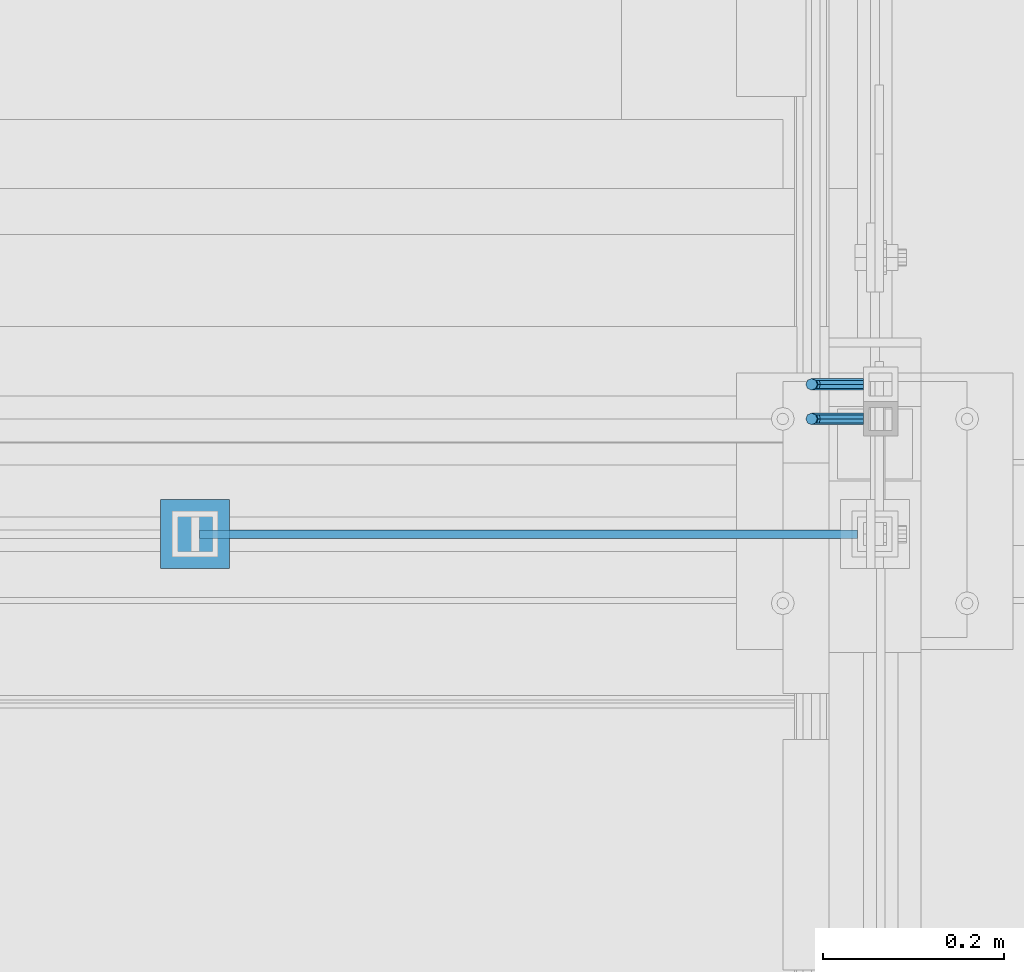
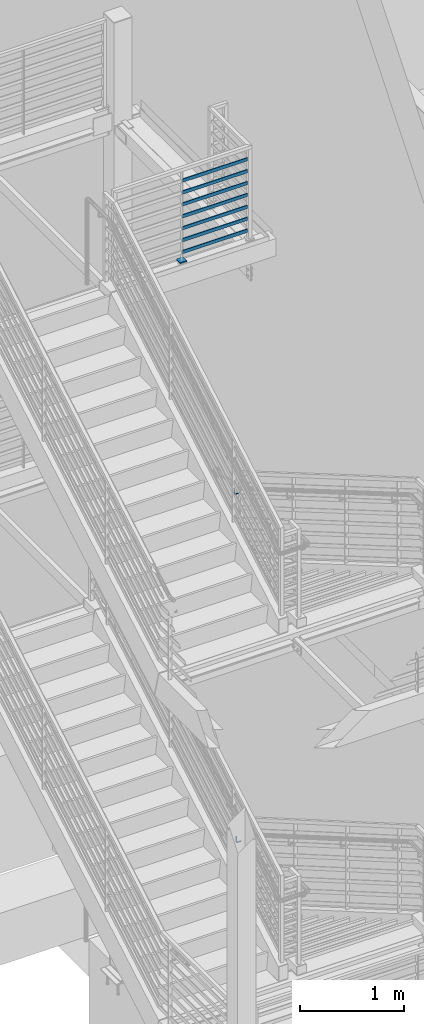
# One storey, part 872 of 1179: 10 beams, 4 elements without a shape of their own.
"""IFC2X3 building model written with IfcOpenShell, lengths in millimetres."""

import ifcopenshell
import ifcopenshell.guid

model = None  # the IFC model being written
_history = None  # IfcOwnerHistory: only IFC2X3 demands one
_inside = {}  # id of a spatial element -> (the spatial element, [elements in it])
_under = {}  # id of a project, library or spatial element -> (it, [spatial elements below it])
_declared = {}  # id of a project -> (the project, [libraries it declares])
_typed = {}  # id of a type object -> (the type object, [elements of that type])
_made_of = {}  # id of a material, layer set ... -> (it, [elements and type objects made of it])


def new_model(schema):
    """Start an empty IFC model of exactly this schema.

    Asked for "IFC4X3", IfcOpenShell would pick the latest addendum, in which some entities
    have other attributes; the version numbers below select the first issue.
    IFC2X3 requires an IfcOwnerHistory on every rooted entity: one is made here for all.
    """
    global model, _history
    if schema == "IFC4X3":
        model = ifcopenshell.file(schema_version=(4, 3, 0, 0))
    else:
        model = ifcopenshell.file(schema=schema)
    _inside.clear()
    _under.clear()
    _declared.clear()
    _typed.clear()
    _made_of.clear()
    _history = None
    if model.schema == "IFC2X3":
        org = make("IfcOrganization", Name="unknown")
        user = make(
            "IfcPersonAndOrganization",
            ThePerson=make("IfcPerson", FamilyName="unknown"),
            TheOrganization=org,
        )
        app = make(
            "IfcApplication",
            ApplicationDeveloper=org,
            Version="unknown",
            ApplicationFullName="unknown",
            ApplicationIdentifier="unknown",
        )
        _history = make(
            "IfcOwnerHistory",
            OwningUser=user,
            OwningApplication=app,
            ChangeAction="ADDED",
            CreationDate=0,
        )
    return model


def make(cls, **values):
    """One entity of the class cls with the attributes given. An attribute that is None is left unset."""
    return model.create_entity(
        cls, **{name: value for name, value in values.items() if value is not None}
    )


def rooted(cls, **values):
    """An entity with a GlobalId (a new one), such as an element, a storey or a relation."""
    return make(cls, GlobalId=ifcopenshell.guid.new(), OwnerHistory=_history, **values)


def si_unit(unit_type, name, prefix=None):
    """IfcSIUnit, for example si_unit("LENGTHUNIT", "METRE", prefix="MILLI")."""
    return make("IfcSIUnit", UnitType=unit_type, Prefix=prefix, Name=name)


def assignment(units):
    """IfcUnitAssignment: the units of a project."""
    return None if units is None else make("IfcUnitAssignment", Units=units)


def point(xyz):
    """IfcCartesianPoint."""
    return None if xyz is None else make("IfcCartesianPoint", Coordinates=xyz)


def direction(xyz):
    """IfcDirection."""
    return None if xyz is None else make("IfcDirection", DirectionRatios=xyz)


def frame(location, z_axis=None, x_axis=None):
    """IfcAxis2Placement3D, a coordinate frame: its origin and axes. An axis left out is left unset."""
    return make(
        "IfcAxis2Placement3D",
        Location=point(location),
        Axis=direction(z_axis),
        RefDirection=direction(x_axis),
    )


def origin_with_axes():
    """The frame at (0, 0, 0) with the z axis (0, 0, 1) and the x axis (1, 0, 0) written out."""
    return frame((0.0, 0.0, 0.0), z_axis=(0.0, 0.0, 1.0), x_axis=(1.0, 0.0, 0.0))


def place(relative_to, where):
    """IfcLocalPlacement: puts the frame where relative to a parent placement (None: the world)."""
    return make(
        "IfcLocalPlacement", PlacementRelTo=relative_to, RelativePlacement=where
    )


def context(
    kind, dimensions, precision=None, world=None, true_north=None, identifier=None
):
    """IfcGeometricRepresentationContext, for example the 3D "Model" context."""
    return make(
        "IfcGeometricRepresentationContext",
        ContextIdentifier=identifier,
        ContextType=kind,
        CoordinateSpaceDimension=dimensions,
        Precision=precision,
        WorldCoordinateSystem=world,
        TrueNorth=true_north,
    )


def subcontext(parent, identifier, kind, view, scale=None):
    """IfcGeometricRepresentationSubContext, for example "Body" below "Model"."""
    return make(
        "IfcGeometricRepresentationSubContext",
        ContextIdentifier=identifier,
        ContextType=kind,
        ParentContext=parent,
        TargetScale=scale,
        TargetView=view,
    )


def project(units=None, contexts=None):
    """IfcProject with its units and contexts."""
    return rooted(
        "IfcProject",
        Name="project",
        RepresentationContexts=contexts,
        UnitsInContext=assignment(units),
    )


def spatial(cls, under=None, at=None, **own):
    """A site, building, storey or space (cls), placed at a placement, below another one or the project."""
    s = rooted(cls, ObjectPlacement=at, **own)
    if under is not None:
        _under.setdefault(under.id(), (under, []))[1].append(s)
    return s


def faces_of(points, faces, orient=None, outer=None):
    """IfcFace entities. A face is a list of loops; a loop is a list of indices into points, from 0.

    orient and outer hold one flag for each loop. By default every Orientation is true, the
    first loop of a face is its IfcFaceOuterBound and the others are IfcFaceBound.
    """
    made = []
    for i, loops in enumerate(faces):
        bounds = []
        for j, loop in enumerate(loops):
            is_outer = j == 0 if outer is None else outer[i][j]
            bounds.append(
                make(
                    "IfcFaceOuterBound" if is_outer else "IfcFaceBound",
                    Bound=make("IfcPolyLoop", Polygon=[points[k] for k in loop]),
                    Orientation=True if orient is None else orient[i][j],
                )
            )
        made.append(make("IfcFace", Bounds=bounds))
    return made


def faceted_brep(points, faces, orient=None, outer=None, voids=None):
    """IfcFacetedBrep: a solid bounded by flat faces; with voids (closed shells), ...WithVoids."""
    shared = [point(p) for p in points]
    hull = make("IfcClosedShell", CfsFaces=faces_of(shared, faces, orient, outer))
    if voids is None:
        return make("IfcFacetedBrep", Outer=hull)
    return make(
        "IfcFacetedBrepWithVoids",
        Outer=hull,
        Voids=[
            make(cls, CfsFaces=faces_of(shared, fs, o, b)) for cls, fs, o, b in voids
        ],
    )


def shape(context_of_items, identifier, shape_type, items):
    """IfcShapeRepresentation: the items that make up one representation, for example the "Body"."""
    return make(
        "IfcShapeRepresentation",
        ContextOfItems=context_of_items,
        RepresentationIdentifier=identifier,
        RepresentationType=shape_type,
        Items=items,
    )


def material(Name=None, Category=None):
    """IfcMaterial."""
    return make("IfcMaterial", Name=Name, Category=Category)


def made_of(thing, what):
    """Note that an element or type object is made of a material, layer set ...; save() writes the relation."""
    if what is not None:
        _made_of.setdefault(what.id(), (what, []))[1].append(thing)
    return thing


def type_object(cls, material=None, **own):
    """A type object (cls), such as IfcWallType, which elements share."""
    return made_of(rooted(cls, **own), material)


def element(
    cls,
    number,
    at=None,
    inside=None,
    cuts=None,
    type_object=None,
    material=None,
    context=None,
    identifier="Body",
    shape_type=None,
    held_by="IfcProductDefinitionShape",
    body=None,
    shapes=None,
    **own,
):
    """One element of the class cls, such as IfcWall. Its Tag is "e" and its number.

    at: its placement. inside: the storey or other place that contains it. cuts: it is an
    opening in that element (IfcRelVoidsElement). A single representation is given by context,
    identifier, shape_type and body (its items); several are given by shapes. held_by: the class
    of the entity that holds the representations. save() writes the other relations.
    """
    e = rooted(cls, Tag="e%d" % number, ObjectPlacement=at, **own)
    if body is not None:
        shapes = [shape(context, identifier, shape_type, body)]
    if shapes is not None:
        e.Representation = make(held_by, Representations=shapes)
    if inside is not None:
        _inside.setdefault(inside.id(), (inside, []))[1].append(e)
    if cuts is not None:
        rooted(
            "IfcRelVoidsElement", RelatingBuildingElement=cuts, RelatedOpeningElement=e
        )
    if type_object is not None:
        _typed.setdefault(type_object.id(), (type_object, []))[1].append(e)
    return made_of(e, material)


def aggregate(whole, parts):
    """IfcRelAggregates: a whole, such as a stair, and the parts it consists of."""
    return rooted("IfcRelAggregates", RelatingObject=whole, RelatedObjects=parts)


def save(model, path):
    """Write the relations noted so far, then the file.

    IfcRelAggregates (storeys below a building ...), IfcRelContainedInSpatialStructure (elements
    in a storey), IfcRelDefinesByType, IfcRelAssociatesMaterial and IfcRelDeclares: one each for
    every whole, place, type object, material and project.
    """
    for whole, parts in _under.values():
        aggregate(whole, parts)
    for where, things in _inside.values():
        rooted(
            "IfcRelContainedInSpatialStructure",
            RelatedElements=things,
            RelatingStructure=where,
        )
    for kind, things in _typed.values():
        rooted("IfcRelDefinesByType", RelatedObjects=things, RelatingType=kind)
    for what, things in _made_of.values():
        rooted("IfcRelAssociatesMaterial", RelatedObjects=things, RelatingMaterial=what)
    for by, libraries in _declared.values():
        rooted("IfcRelDeclares", RelatingContext=by, RelatedDefinitions=libraries)
    model.write(path)


model = new_model("IFC2X3")

# Units and contexts
model_context = context("Model", 3, precision=1e-05, world=origin_with_axes())
body_context = subcontext(model_context, "Body", "Model", "MODEL_VIEW")
ifc_project = project(units=[si_unit("LENGTHUNIT", "METRE", prefix="MILLI"), si_unit("AREAUNIT", "SQUARE_METRE"), si_unit("VOLUMEUNIT", "CUBIC_METRE"), si_unit("MASSUNIT", "GRAM", prefix="KILO"), si_unit("TIMEUNIT", "SECOND"), si_unit("PLANEANGLEUNIT", "RADIAN"), si_unit("SOLIDANGLEUNIT", "STERADIAN"), si_unit("THERMODYNAMICTEMPERATUREUNIT", "DEGREE_CELSIUS"), si_unit("LUMINOUSINTENSITYUNIT", "LUMEN")], contexts=[model_context])

# Site, building, storey
site_placement = place(None, origin_with_axes())
site = spatial("IfcSite", under=ifc_project, at=site_placement, CompositionType="ELEMENT")
building_placement = place(site_placement, origin_with_axes())
building = spatial("IfcBuilding", under=site, at=building_placement, Name="Undefined", CompositionType="ELEMENT")
storey_placement = place(building_placement, origin_with_axes())
storey = spatial("IfcBuildingStorey", under=building, at=storey_placement, Name="Undefined", CompositionType="ELEMENT", Elevation=0.0)

# Assembly, beam
assembly_1_placement = place(storey_placement, origin_with_axes())
assembly_1 = element("IfcElementAssembly", 1, at=assembly_1_placement, inside=storey, Name="GUARDRAIL", AssemblyPlace="NOTDEFINED", PredefinedType="RIGID_FRAME")
ifc_material = material(Name="STEEL/A36")
beam_type_1 = type_object("IfcBeamType", PredefinedType="NOTDEFINED")
beam_1_placement = place(assembly_1_placement, frame((-266.699999255495, 35280.5999999097, 5054.60000718302), z_axis=(0.0, 0.0, 1.0), x_axis=(-1.0, 0.0, 0.0)))
beam_1 = element("IfcBeam", 2, at=beam_1_placement, type_object=beam_type_1, material=ifc_material, Name="BRACKET", context=body_context, shape_type="Brep", body=[
    faceted_brep([(0.0, -4.49012806053361, 4.49012806053452), (0.0, 0.0, 6.34999999999991), (0.0, 4.49012806053361, 4.49012806053452), (0.0, 6.34999999999854, 0.0), (0.0, 4.49012806053361, -4.49012806053452), (0.0, 0.0, -6.34999999999991), (0.0, -4.49012806053361, -4.49012806053452), (0.0, -6.34999999999854, 0.0), (44.4500031699827, 0.0, -6.34999999999991), (44.4500031699827, -4.49012806053361, -4.49012806053452), (44.4500031699827, -6.34999999999854, 2.19733919948339e-09), (44.4500031699827, -4.49012806053361, 4.49012806053452), (44.4500031699827, 0.0, 6.34999999999991), (44.4500031699827, 4.49012806053361, 4.49012806053452), (44.4500031699827, 6.34999999999854, 0.0), (44.4500031699827, 4.49012806053361, -4.49012806053452), (53.0450671075391, 4.4901280570557, -2.18708762112465), (53.97500307462, -4.32919478043914e-09, -3.79778396764459), (53.0450671022344, -4.49012806401151, -2.1870876194389), (50.8000030708674, -6.35000000142099, 1.70147734757802), (48.5549390416977, -4.4901280599006, 5.59004231389645), (47.6250030746168, 1.48793333210051e-09, 7.20073866041594), (48.5549390470023, 4.49012806117025, 5.5900423122107), (50.8000030783693, 6.34999999857973, 1.70147734519378), (55.4485256393576, 6.34999999469437, 6.34999990618098), (59.337090604122, 4.49012805180246, 4.10493587545716), (51.5599606707875, 4.49012805866005, 8.59506393599531), (49.9492643188311, -4.54747350886464e-10, 9.52499990463002), (51.5599606615996, -4.4901280624108, 8.59506393379797), (55.4485256263639, -6.35000000530636, 6.34999990307369), (59.337090594938, -4.49012806926839, 4.10493587326664), (60.9477869468905, -1.0153598850593e-08, 3.17499990462466), (61.6401310450869, 4.49012804462109, 12.6999998130159), (63.5000029792477, -1.81098585017025e-08, 12.6999998092651), (57.1500029867496, 6.3499999893902, 12.6999998145698), (52.6598749240178, 4.49012805522943, 12.6999998130159), (50.8000029792477, -3.10683390125632e-09, 12.6999998092651), (52.6598749134085, -4.49012806583778, 12.6999998055144), (57.1500029739432, -6.35000001061053, 12.6999998039605), (61.6401310344776, -4.49012807644976, 12.6999998055144), (63.5000029792478, -6.94672053214163e-08, 76.1999999999989), (61.6401310356729, -4.49012812829824, 76.1999999999989), (57.1500029739432, -6.3500000636559, 76.1999999999989), (52.6598749146037, -4.49012812008004, 76.1999999999989), (50.8000029792478, -5.78438630327582e-08, 76.1999999999989), (52.6598749228227, 4.49012800098717, 76.1999999999989), (57.1500029850595, 6.34999993634483, 76.1999999999989), (61.6401310438919, 4.49012799276898, 76.1999999999989)], [[[0, 1, 2, 3, 4, 5, 6, 7]], [[6, 5, 8, 9]], [[7, 6, 9, 10]], [[0, 7, 10, 11]], [[1, 0, 11, 12]], [[2, 1, 12, 13]], [[3, 2, 13, 14]], [[4, 3, 14, 15]], [[5, 4, 15, 8]], [[8, 15, 16, 17]], [[9, 8, 17, 18]], [[10, 9, 18, 19]], [[11, 10, 19, 20]], [[12, 11, 20, 21]], [[13, 12, 21, 22]], [[14, 13, 22, 23]], [[15, 14, 23, 16]], [[23, 24, 25, 16]], [[22, 26, 24, 23]], [[21, 27, 26, 22]], [[20, 28, 27, 21]], [[19, 29, 28, 20]], [[18, 30, 29, 19]], [[17, 31, 30, 18]], [[16, 25, 31, 17]], [[25, 32, 33, 31]], [[24, 34, 32, 25]], [[26, 35, 34, 24]], [[27, 36, 35, 26]], [[28, 37, 36, 27]], [[29, 38, 37, 28]], [[30, 39, 38, 29]], [[31, 33, 39, 30]], [[39, 33, 40, 41]], [[38, 39, 41, 42]], [[37, 38, 42, 43]], [[36, 37, 43, 44]], [[35, 36, 44, 45]], [[34, 35, 45, 46]], [[32, 34, 46, 47]], [[33, 32, 47, 40]], [[46, 45, 44, 43, 42, 41, 40, 47]]]),
])
aggregate(assembly_1, [beam_1])

assembly_2_placement = place(storey_placement, origin_with_axes())
assembly_2 = element("IfcElementAssembly", 3, at=assembly_2_placement, inside=storey, Name="GUARDRAIL", AssemblyPlace="NOTDEFINED", PredefinedType="RIGID_FRAME")
beam_2_placement = place(assembly_2_placement, frame((-266.699999255495, 35242.5000011132, 992.66520504755), z_axis=(0.0, 0.0, 1.0), x_axis=(-1.0, 0.0, 0.0)))
beam_2 = element("IfcBeam", 4, at=beam_2_placement, type_object=beam_type_1, material=ifc_material, Name="BRACKET", context=body_context, shape_type="Brep", body=[
    faceted_brep([(0.0, -4.49012806053361, 4.49012806053452), (0.0, 0.0, 6.34999999999991), (0.0, 4.49012806053361, 4.49012806053452), (0.0, 6.34999999999854, 0.0), (0.0, 4.49012806053361, -4.49012806053452), (0.0, 0.0, -6.34999999999991), (0.0, -4.49012806053361, -4.49012806053452), (0.0, -6.34999999999854, 0.0), (44.4500031699827, 0.0, -6.34999999999991), (44.4500031699827, -4.49012806053361, -4.49012806053452), (44.4500031699827, -6.34999999999854, 2.19733919948339e-09), (44.4500031699827, -4.49012806053361, 4.49012806053452), (44.4500031699827, 0.0, 6.34999999999991), (44.4500031699827, 4.49012806053361, 4.49012806053452), (44.4500031699827, 6.34999999999854, 0.0), (44.4500031699827, 4.49012806053361, -4.49012806053452), (53.0450671075391, 4.4901280570557, -2.18708762112465), (53.97500307462, -4.32919478043914e-09, -3.79778396764459), (53.0450671022344, -4.49012806401151, -2.1870876194389), (50.8000030708674, -6.35000000142099, 1.70147734757802), (48.5549390416977, -4.4901280599006, 5.59004231389645), (47.6250030746168, 1.48793333210051e-09, 7.20073866041594), (48.5549390470023, 4.49012806117025, 5.5900423122107), (50.8000030783693, 6.34999999857973, 1.70147734519378), (55.4485256393576, 6.34999999469437, 6.34999990618098), (59.337090604122, 4.49012805180246, 4.10493587545716), (51.5599606707875, 4.49012805866005, 8.59506393599531), (49.9492643188311, -4.54747350886464e-10, 9.52499990463002), (51.5599606615996, -4.4901280624108, 8.59506393379797), (55.4485256263639, -6.35000000530636, 6.34999990307369), (59.337090594938, -4.49012806926839, 4.10493587326664), (60.9477869468905, -1.0153598850593e-08, 3.17499990462466), (61.6401310450869, 4.49012804462109, 12.6999998130159), (63.5000029792477, -1.81098585017025e-08, 12.6999998092651), (57.1500029867496, 6.3499999893902, 12.6999998145698), (52.6598749240178, 4.49012805522943, 12.6999998130159), (50.8000029792477, -3.10683390125632e-09, 12.6999998092651), (52.6598749134085, -4.49012806583778, 12.6999998055144), (57.1500029739432, -6.35000001061053, 12.6999998039605), (61.6401310344776, -4.49012807644976, 12.6999998055144), (63.5000029792478, -6.94672053214163e-08, 76.1999999999989), (61.6401296086745, -4.49012715444769, 73.6001774342253), (57.1500015634042, -6.3499991642384, 72.5232956440923), (52.6598734876054, -4.49012727027366, 73.6001773671605), (50.8000029792478, -5.78438630327582e-08, 76.1999999999989), (52.6598733730815, 4.4901289120171, 78.79982245163), (57.150001410549, 6.35000092050541, 79.8767042410086), (61.6401294941506, 4.49012902523828, 78.7998225171859)], [[[0, 1, 2, 3, 4, 5, 6, 7]], [[6, 5, 8, 9]], [[7, 6, 9, 10]], [[0, 7, 10, 11]], [[1, 0, 11, 12]], [[2, 1, 12, 13]], [[3, 2, 13, 14]], [[4, 3, 14, 15]], [[5, 4, 15, 8]], [[8, 15, 16, 17]], [[9, 8, 17, 18]], [[10, 9, 18, 19]], [[11, 10, 19, 20]], [[12, 11, 20, 21]], [[13, 12, 21, 22]], [[14, 13, 22, 23]], [[15, 14, 23, 16]], [[23, 24, 25, 16]], [[22, 26, 24, 23]], [[21, 27, 26, 22]], [[20, 28, 27, 21]], [[19, 29, 28, 20]], [[18, 30, 29, 19]], [[17, 31, 30, 18]], [[16, 25, 31, 17]], [[25, 32, 33, 31]], [[24, 34, 32, 25]], [[26, 35, 34, 24]], [[27, 36, 35, 26]], [[28, 37, 36, 27]], [[29, 38, 37, 28]], [[30, 39, 38, 29]], [[31, 33, 39, 30]], [[39, 33, 40, 41]], [[38, 39, 41, 42]], [[37, 38, 42, 43]], [[36, 37, 43, 44]], [[35, 36, 44, 45]], [[34, 35, 45, 46]], [[32, 34, 46, 47]], [[33, 32, 47, 40]], [[46, 45, 44, 43, 42, 41, 40, 47]]]),
])
aggregate(assembly_2, [beam_2])

# Assembly, beams
assembly_3_placement = place(storey_placement, origin_with_axes())
assembly_3 = element("IfcElementAssembly", 5, at=assembly_3_placement, inside=storey, Name="GUARDRAIL", AssemblyPlace="NOTDEFINED", PredefinedType="RIGID_FRAME")
beam_type_2 = type_object("IfcBeamType", PredefinedType="NOTDEFINED")
beam_3_placement = place(assembly_3_placement, frame((-1003.29930604146, 35115.5, 8235.94814466621), z_axis=(0.0, 0.0, 1.0), x_axis=(1.0, 0.0, 0.0)))
beam_3 = element("IfcBeam", 6, at=beam_3_placement, type_object=beam_type_2, material=ifc_material, Name="PLATE", context=body_context, shape_type="Brep", body=[
    faceted_brep([(4.76180372250008, 4.76249999999709, -19.0499999999993), (4.76180372250008, 4.76249999999709, 19.0499999999993), (730.249302168546, 4.76249999999709, 19.0499999999993), (730.249302168546, 4.76249999999709, -19.0499999999993), (4.76180372250008, -4.76249999999709, 19.0499999999993), (730.249302168546, -4.76249999999709, 19.0499999999993), (4.76180372250008, -4.76249999999709, -19.0499999999993), (730.249302168546, -4.76249999999709, -19.0499999999993)], [[[0, 1, 2, 3]], [[1, 4, 5, 2]], [[4, 6, 7, 5]], [[6, 0, 3, 7]], [[5, 7, 3, 2]], [[6, 4, 1, 0]]]),
])
beam_4_placement = place(assembly_3_placement, frame((-1003.29930604146, 35115.5, 8375.64814466621), z_axis=(0.0, 0.0, 1.0), x_axis=(1.0, 0.0, 0.0)))
beam_4 = element("IfcBeam", 7, at=beam_4_placement, type_object=beam_type_2, material=ifc_material, Name="PLATE", context=body_context, shape_type="Brep", body=[
    faceted_brep([(4.76180372250008, 4.76249999999709, -19.0499999999993), (4.76180372250008, 4.76249999999709, 19.0499999999993), (730.249302168546, 4.76249999999709, 19.0499999999993), (730.249302168546, 4.76249999999709, -19.0499999999993), (4.76180372250008, -4.76249999999709, 19.0499999999993), (730.249302168546, -4.76249999999709, 19.0499999999993), (4.76180372250008, -4.76249999999709, -19.0499999999993), (730.249302168546, -4.76249999999709, -19.0499999999993)], [[[0, 1, 2, 3]], [[1, 4, 5, 2]], [[4, 6, 7, 5]], [[6, 0, 3, 7]], [[5, 7, 3, 2]], [[6, 4, 1, 0]]]),
])
beam_5_placement = place(assembly_3_placement, frame((-1003.29930604146, 35115.5, 8515.34814466621), z_axis=(0.0, 0.0, 1.0), x_axis=(1.0, 0.0, 0.0)))
beam_5 = element("IfcBeam", 8, at=beam_5_placement, type_object=beam_type_2, material=ifc_material, Name="PLATE", context=body_context, shape_type="Brep", body=[
    faceted_brep([(4.76180372250008, 4.76249999999709, -19.0499999999993), (4.76180372250008, 4.76249999999709, 19.0499999999993), (730.249302168546, 4.76249999999709, 19.0499999999993), (730.249302168546, 4.76249999999709, -19.0499999999993), (4.76180372250008, -4.76249999999709, 19.0499999999993), (730.249302168546, -4.76249999999709, 19.0499999999993), (4.76180372250008, -4.76249999999709, -19.0499999999993), (730.249302168546, -4.76249999999709, -19.0499999999993)], [[[0, 1, 2, 3]], [[1, 4, 5, 2]], [[4, 6, 7, 5]], [[6, 0, 3, 7]], [[5, 7, 3, 2]], [[6, 4, 1, 0]]]),
])
beam_6_placement = place(assembly_3_placement, frame((-1003.29930604146, 35115.5, 8655.0481446662), z_axis=(0.0, 0.0, 1.0), x_axis=(1.0, 0.0, 0.0)))
beam_6 = element("IfcBeam", 9, at=beam_6_placement, type_object=beam_type_2, material=ifc_material, Name="PLATE", context=body_context, shape_type="Brep", body=[
    faceted_brep([(4.76180372250008, 4.76249999999709, -19.0499999999993), (4.76180372250008, 4.76249999999709, 19.0499999999993), (730.249302168546, 4.76249999999709, 19.0499999999993), (730.249302168546, 4.76249999999709, -19.0499999999993), (4.76180372250008, -4.76249999999709, 19.0499999999993), (730.249302168546, -4.76249999999709, 19.0499999999993), (4.76180372250008, -4.76249999999709, -19.0499999999993), (730.249302168546, -4.76249999999709, -19.0499999999993)], [[[0, 1, 2, 3]], [[1, 4, 5, 2]], [[4, 6, 7, 5]], [[6, 0, 3, 7]], [[5, 7, 3, 2]], [[6, 4, 1, 0]]]),
])
beam_7_placement = place(assembly_3_placement, frame((-1003.29930604146, 35115.5, 8794.7481446662), z_axis=(0.0, 0.0, 1.0), x_axis=(1.0, 0.0, 0.0)))
beam_7 = element("IfcBeam", 10, at=beam_7_placement, type_object=beam_type_2, material=ifc_material, Name="PLATE", context=body_context, shape_type="Brep", body=[
    faceted_brep([(4.76180372250008, 4.76249999999709, -19.0499999999993), (4.76180372250008, 4.76249999999709, 19.0499999999993), (730.249302168546, 4.76249999999709, 19.0499999999993), (730.249302168546, 4.76249999999709, -19.0499999999993), (4.76180372250008, -4.76249999999709, 19.0499999999993), (730.249302168546, -4.76249999999709, 19.0499999999993), (4.76180372250008, -4.76249999999709, -19.0499999999993), (730.249302168546, -4.76249999999709, -19.0499999999993)], [[[0, 1, 2, 3]], [[1, 4, 5, 2]], [[4, 6, 7, 5]], [[6, 0, 3, 7]], [[5, 7, 3, 2]], [[6, 4, 1, 0]]]),
])
beam_8_placement = place(assembly_3_placement, frame((-1003.29930604146, 35115.5, 8934.4481446662), z_axis=(0.0, 0.0, 1.0), x_axis=(1.0, 0.0, 0.0)))
beam_8 = element("IfcBeam", 11, at=beam_8_placement, type_object=beam_type_2, material=ifc_material, Name="PLATE", context=body_context, shape_type="Brep", body=[
    faceted_brep([(4.76180372250008, 4.76249999999709, -19.0499999999993), (4.76180372250008, 4.76249999999709, 19.0499999999993), (730.249302168546, 4.76249999999709, 19.0499999999993), (730.249302168546, 4.76249999999709, -19.0499999999993), (4.76180372250008, -4.76249999999709, 19.0499999999993), (730.249302168546, -4.76249999999709, 19.0499999999993), (4.76180372250008, -4.76249999999709, -19.0499999999993), (730.249302168546, -4.76249999999709, -19.0499999999993)], [[[0, 1, 2, 3]], [[1, 4, 5, 2]], [[4, 6, 7, 5]], [[6, 0, 3, 7]], [[5, 7, 3, 2]], [[6, 4, 1, 0]]]),
])
beam_9_placement = place(assembly_3_placement, frame((-1003.29930604146, 35115.5, 9074.14814466619), z_axis=(0.0, 0.0, 1.0), x_axis=(1.0, 0.0, 0.0)))
beam_9 = element("IfcBeam", 12, at=beam_9_placement, type_object=beam_type_2, material=ifc_material, Name="PLATE", context=body_context, shape_type="Brep", body=[
    faceted_brep([(4.76180372250008, 4.76249999999709, -19.0499999999993), (4.76180372250008, 4.76249999999709, 19.0499999999993), (730.249302168546, 4.76249999999709, 19.0499999999993), (730.249302168546, 4.76249999999709, -19.0499999999993), (4.76180372250008, -4.76249999999709, 19.0499999999993), (730.249302168546, -4.76249999999709, 19.0499999999993), (4.76180372250008, -4.76249999999709, -19.0499999999993), (730.249302168546, -4.76249999999709, -19.0499999999993)], [[[0, 1, 2, 3]], [[1, 4, 5, 2]], [[4, 6, 7, 5]], [[6, 0, 3, 7]], [[5, 7, 3, 2]], [[6, 4, 1, 0]]]),
])
aggregate(assembly_3, [beam_3, beam_4, beam_5, beam_6, beam_7, beam_8, beam_9])

# Assembly, beam
assembly_4_placement = place(storey_placement, origin_with_axes())
assembly_4 = element("IfcElementAssembly", 13, at=assembly_4_placement, inside=storey, Name="SLEEVE", AssemblyPlace="NOTDEFINED", PredefinedType="RIGID_FRAME")
beam_type_3 = type_object("IfcBeamType", PredefinedType="NOTDEFINED")
beam_10_placement = place(assembly_4_placement, frame((-1041.40000231896, 35115.5, 8140.75477407027), z_axis=(0.0, 1.0, 0.0), x_axis=(1.0, 0.0, 0.0)))
beam_10 = element("IfcBeam", 14, at=beam_10_placement, type_object=beam_type_3, material=ifc_material, Name="PLATE", context=body_context, shape_type="Brep", body=[
    faceted_brep([(0.0, 6.35000000000036, -38.0999999999985), (0.0, 6.35000000000036, 38.0999999999985), (76.2, 6.35000000000036, 38.0999999999985), (76.2, 6.35000000000036, -38.0999999999985), (0.0, -6.35000000000036, 38.0999999999985), (76.2, -6.35000000000036, 38.0999999999985), (0.0, -6.35000000000036, -38.0999999999985), (76.2, -6.35000000000036, -38.0999999999985)], [[[0, 1, 2, 3]], [[1, 4, 5, 2]], [[4, 6, 7, 5]], [[6, 0, 3, 7]], [[5, 7, 3, 2]], [[6, 4, 1, 0]]]),
])
aggregate(assembly_4, [beam_10])

save(model, "model.ifc")
